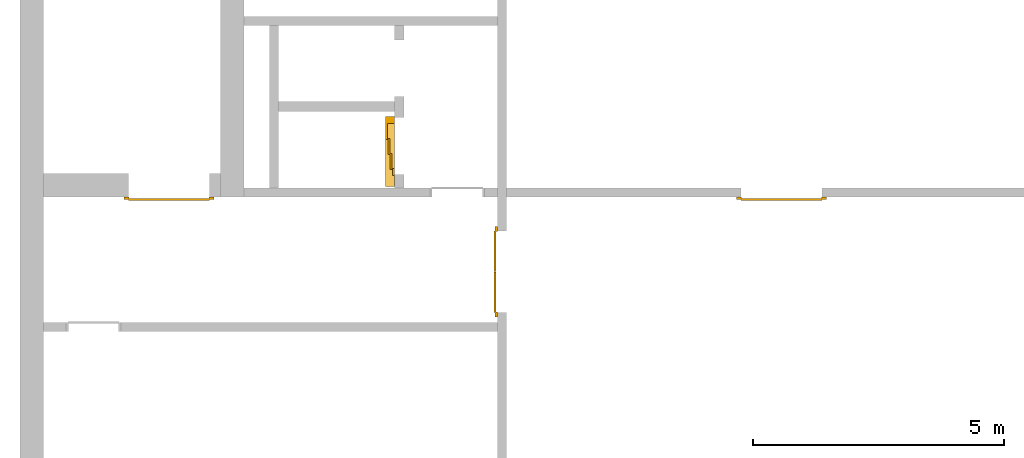
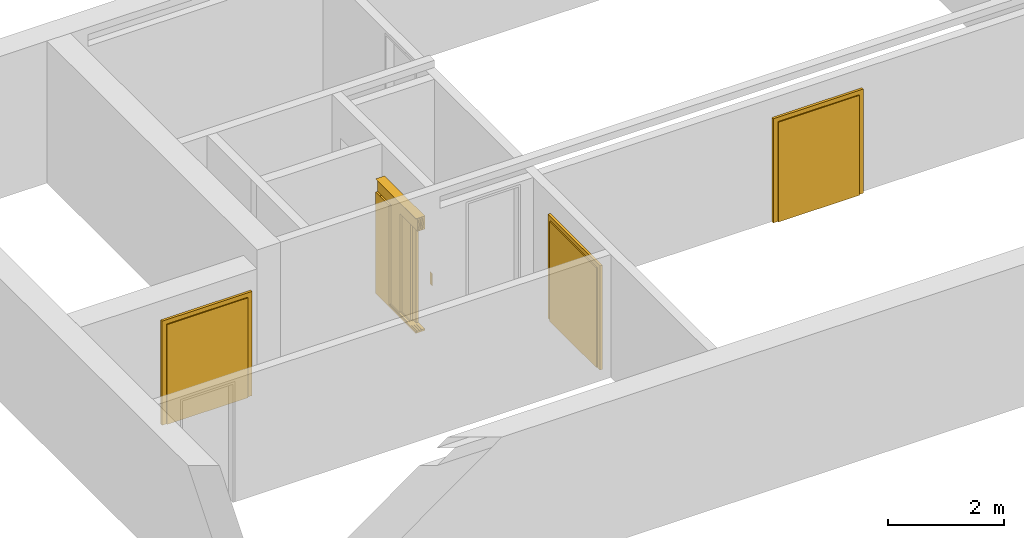
# One storey, part 2 of 3: 4 doors.
"""IFC4 building model written with IfcOpenShell, lengths in metres."""

from ifc_helpers import new_model, entity, si_unit, converted_unit, derived_unit, direction, frame, origin_with_axes, place, context, subcontext, project, spatial, polygons, source, transform, mapped, type_object, element, save


model = new_model("IFC4")

# Units and contexts
model_context = context("Model", 3, precision=1e-05, world=origin_with_axes(), true_north=direction((0.0, 1.0)))
body_context = subcontext(model_context, "Body", "Model", "MODEL_VIEW")
ifc_project = project(units=[si_unit("LENGTHUNIT", "METRE"), si_unit("AREAUNIT", "SQUARE_METRE"), si_unit("VOLUMEUNIT", "CUBIC_METRE"), converted_unit("PLANEANGLEUNIT", "DEGREE", entity("IfcPlaneAngleMeasure", 0.0174532925199433), si_unit("PLANEANGLEUNIT", "RADIAN"), dimensions=[0, 0, 0, 0, 0, 0, 0]), converted_unit("TIMEUNIT", "Year", entity("IfcTimeMeasure", 31557600.0), si_unit("TIMEUNIT", "SECOND"), dimensions=[0, 0, 1, 0, 0, 0, 0]), si_unit("MASSUNIT", "GRAM", prefix="KILO"), si_unit("THERMODYNAMICTEMPERATUREUNIT", "DEGREE_CELSIUS"), si_unit("LUMINOUSINTENSITYUNIT", "LUMEN"), si_unit("ENERGYUNIT", "JOULE", prefix="MEGA"), derived_unit("THERMALCONDUCTANCEUNIT", [(si_unit("POWERUNIT", "WATT"), 1), (si_unit("LENGTHUNIT", "METRE"), -1), (si_unit("THERMODYNAMICTEMPERATUREUNIT", "KELVIN"), -1)]), derived_unit("SPECIFICHEATCAPACITYUNIT", [(si_unit("ENERGYUNIT", "JOULE"), 1), (si_unit("MASSUNIT", "GRAM", prefix="KILO"), -1), (si_unit("THERMODYNAMICTEMPERATUREUNIT", "KELVIN"), -1)]), derived_unit("MASSDENSITYUNIT", [(si_unit("MASSUNIT", "GRAM", prefix="KILO"), 1), (si_unit("VOLUMEUNIT", "CUBIC_METRE"), -1)])], contexts=[model_context])

# Site, building, storey
site_placement = place(None, origin_with_axes())
site = spatial("IfcSite", under=ifc_project, at=site_placement, CompositionType="ELEMENT")
building_placement = place(None, origin_with_axes())
building = spatial("IfcBuilding", under=site, at=building_placement, CompositionType="ELEMENT")
storey_placement = place(None, frame((0.0, 0.0, -3.0), z_axis=(0.0, 0.0, 1.0), x_axis=(1.0, 0.0, 0.0)))
storey = spatial("IfcBuildingStorey", under=building, at=storey_placement, Name="UG", CompositionType="ELEMENT", Elevation=-3.0)

# Doors
door_type_1 = type_object("IfcDoorType", OperationType="DOUBLE_DOOR_SINGLE_SWING", PredefinedType="DOOR")
shared_shape_1 = source(origin_with_axes(), body_context, "Body", "Tessellation", [
    polygons([(-0.9, 0.0, 0.0), (-0.9, 0.0, 2.2), (-0.9, 0.03, 2.2), (-0.9, 0.03, 0.0), (-0.8, 0.0, 0.0), (-0.8, 0.0, 2.1), (-0.1101, 0.0, 2.1), (-0.0001, 0.0, 2.1), (0.8, 0.0, 2.1), (0.8, 0.0, 0.0), (0.9, 0.0, 0.0), (0.9, 0.0, 2.2), (0.9, 0.03, 2.2), (0.9, 0.03, 0.0), (0.8, 0.03, 0.0), (0.8, 0.03, 2.1), (-0.0001, 0.03, 2.1), (-0.1101, 0.03, 2.1), (-0.8, 0.03, 2.1), (-0.8, 0.03, 0.0)], [[[1, 2, 3, 4]], [[1, 5, 6, 7, 8, 9, 10, 11, 12, 2]], [[2, 12, 13, 3]], [[4, 3, 13, 14, 15, 16, 17, 18, 19, 20]], [[5, 1, 4, 20]], [[6, 5, 20, 19]], [[7, 6, 19, 18]], [[8, 7, 18, 17]], [[9, 8, 17, 16]], [[10, 9, 16, 15]], [[11, 10, 15, 14]], [[12, 11, 14, 13]]], closed=True),
    polygons([(-0.9, 0.03, 0.0), (-0.9, 0.03, 2.2), (-0.9, 0.05, 2.2), (-0.9, 0.05, 0.0), (-0.81, 0.03, 0.0), (-0.81, 0.03, 2.11), (-0.1001, 0.03, 2.11), (-0.0101, 0.03, 2.11), (0.81, 0.03, 2.11), (0.81, 0.03, 0.0), (0.9, 0.03, 0.0), (0.9, 0.03, 2.2), (0.9, 0.05, 2.2), (0.9, 0.05, 0.0), (0.81, 0.05, 0.0), (0.81, 0.05, 2.11), (-0.0101, 0.05, 2.11), (-0.1001, 0.05, 2.11), (-0.81, 0.05, 2.11), (-0.81, 0.05, 0.0)], [[[1, 2, 3, 4]], [[1, 5, 6, 7, 8, 9, 10, 11, 12, 2]], [[2, 12, 13, 3]], [[4, 3, 13, 14, 15, 16, 17, 18, 19, 20]], [[5, 1, 4, 20]], [[6, 5, 20, 19]], [[7, 6, 19, 18]], [[8, 7, 18, 17]], [[9, 8, 17, 16]], [[10, 9, 16, 15]], [[11, 10, 15, 14]], [[12, 11, 14, 13]]], closed=True),
    polygons([(-0.81, 0.07, 0.0), (-0.81, 0.07, 2.11), (-0.000499999999999945, 0.07, 2.11), (-0.000499999999999945, 0.07, 0.0), (-0.81, 0.03, 0.0), (-0.81, 0.03, 2.11), (-0.000499999999999945, 0.03, 2.11), (-0.000499999999999945, 0.03, 0.0)], [[[1, 2, 3, 4]], [[1, 5, 6, 2]], [[2, 6, 7, 3]], [[3, 7, 8, 4]], [[4, 8, 5, 1]], [[8, 7, 6, 5]]], closed=True),
    polygons([(0.81, 0.07, 0.0), (0.000499999999999945, 0.07, 0.0), (0.000499999999999945, 0.07, 2.11), (0.81, 0.07, 2.11), (0.81, 0.03, 0.0), (0.000499999999999945, 0.03, 0.0), (0.000499999999999945, 0.03, 2.11), (0.81, 0.03, 2.11)], [[[1, 2, 3, 4]], [[2, 1, 5, 6]], [[3, 2, 6, 7]], [[4, 3, 7, 8]], [[1, 4, 8, 5]], [[6, 5, 8, 7]]], closed=True),
])
door_1_placement = place(None, frame((39.968657642847, 7.05499994546755, -3.0), z_axis=(0.0, 0.0, 1.0), x_axis=(-1.0, 0.0, 0.0)))
element("IfcDoor", 1, at=door_1_placement, inside=storey, type_object=door_type_1, OverallHeight=2.11, OverallWidth=1.62, context=body_context, shape_type="MappedRepresentation", body=[
    mapped(shared_shape_1, transform((0.799999999999997, 0.0, 0.0))),
])
door_2_placement = place(None, frame((33.505, 4.76499994546756, -3.0), z_axis=(0.0, 0.0, 1.0), x_axis=(0.0, 1.0, 0.0)))
element("IfcDoor", 2, at=door_2_placement, inside=storey, type_object=door_type_1, OverallHeight=2.11, OverallWidth=1.62, context=body_context, shape_type="MappedRepresentation", body=[
    mapped(shared_shape_1, transform((0.8, 0.0, 0.0))),
])
shared_shape_2 = source(origin_with_axes(), body_context, "Body", "Tessellation", [
    polygons([(-0.9, 0.0, 0.0), (-0.9, 0.0, 2.2), (-0.9, 0.03, 2.2), (-0.9, 0.03, 0.0), (-0.8, 0.0, 0.0), (-0.8, 0.0, 2.1), (-0.1101, 0.0, 2.1), (-0.0001, 0.0, 2.1), (0.8, 0.0, 2.1), (0.8, 0.0, 0.0), (0.9, 0.0, 0.0), (0.9, 0.0, 2.2), (0.9, 0.03, 2.2), (0.9, 0.03, 0.0), (0.8, 0.03, 0.0), (0.8, 0.03, 2.1), (-0.0001, 0.03, 2.1), (-0.1101, 0.03, 2.1), (-0.8, 0.03, 2.1), (-0.8, 0.03, 0.0)], [[[1, 2, 3, 4]], [[1, 5, 6, 7, 8, 9, 10, 11, 12, 2]], [[2, 12, 13, 3]], [[4, 3, 13, 14, 15, 16, 17, 18, 19, 20]], [[5, 1, 4, 20]], [[6, 5, 20, 19]], [[7, 6, 19, 18]], [[8, 7, 18, 17]], [[9, 8, 17, 16]], [[10, 9, 16, 15]], [[11, 10, 15, 14]], [[12, 11, 14, 13]]], closed=True),
    polygons([(-0.9, 0.03, 0.0), (-0.9, 0.03, 2.2), (-0.9, 0.05, 2.2), (-0.9, 0.05, 0.0), (-0.81, 0.03, 0.0), (-0.81, 0.03, 2.11), (-0.1001, 0.03, 2.11), (-0.0101, 0.03, 2.11), (0.81, 0.03, 2.11), (0.81, 0.03, 0.0), (0.9, 0.03, 0.0), (0.9, 0.03, 2.2), (0.9, 0.05, 2.2), (0.9, 0.05, 0.0), (0.81, 0.05, 0.0), (0.81, 0.05, 2.11), (-0.0101, 0.05, 2.11), (-0.1001, 0.05, 2.11), (-0.81, 0.05, 2.11), (-0.81, 0.05, 0.0)], [[[1, 2, 3, 4]], [[1, 5, 6, 7, 8, 9, 10, 11, 12, 2]], [[2, 12, 13, 3]], [[4, 3, 13, 14, 15, 16, 17, 18, 19, 20]], [[5, 1, 4, 20]], [[6, 5, 20, 19]], [[7, 6, 19, 18]], [[8, 7, 18, 17]], [[9, 8, 17, 16]], [[10, 9, 16, 15]], [[11, 10, 15, 14]], [[12, 11, 14, 13]]], closed=True),
    polygons([(-0.81, 0.07, 0.0), (-0.81, 0.07, 2.11), (-0.000499999999999945, 0.07, 2.11), (-0.000499999999999945, 0.07, 0.0), (-0.81, 0.03, 0.0), (-0.81, 0.03, 2.11), (-0.000499999999999945, 0.03, 2.11), (-0.000499999999999945, 0.03, 0.0)], [[[1, 2, 3, 4]], [[1, 5, 6, 2]], [[2, 6, 7, 3]], [[3, 7, 8, 4]], [[4, 8, 5, 1]], [[8, 7, 6, 5]]], closed=True),
    polygons([(0.81, 0.07, 0.0), (0.000499999999999945, 0.07, 0.0), (0.000499999999999945, 0.07, 2.11), (0.81, 0.07, 2.11), (0.81, 0.03, 0.0), (0.000499999999999945, 0.03, 0.0), (0.000499999999999945, 0.03, 2.11), (0.81, 0.03, 2.11)], [[[1, 2, 3, 4]], [[2, 1, 5, 6]], [[3, 2, 6, 7]], [[4, 3, 7, 8]], [[1, 4, 8, 5]], [[6, 5, 8, 7]]], closed=True),
])
door_3_placement = place(None, frame((27.758, 7.05499994546755, -3.0), z_axis=(0.0, 0.0, 1.0), x_axis=(-1.0, 0.0, 0.0)))
element("IfcDoor", 3, at=door_3_placement, inside=storey, type_object=door_type_1, OverallHeight=2.11, OverallWidth=1.62, context=body_context, shape_type="MappedRepresentation", body=[
    mapped(shared_shape_2, transform((0.800000000000001, 0.0, 0.0))),
])
door_type_2 = type_object("IfcDoorType", Name="27", OperationType="DOUBLE_DOOR_SLIDING", PredefinedType="DOOR")
shared_shape_3 = source(origin_with_axes(), body_context, "Body", "Tessellation", [
    polygons([(-0.808333333333334, 0.135, 2.1), (-0.808333333333334, 0.135, 2.138), (0.585, 0.135, 2.138), (0.585, 0.135, 2.1), (-0.808333333333334, 0.0, 2.1), (-0.808333333333334, 0.0, 2.38), (-0.808333333333334, 0.18, 2.38), (-0.808333333333334, 0.18, 2.377), (-0.808333333333334, 0.003, 2.377), (-0.808333333333334, 0.003, 2.103), (-0.808333333333334, 0.132, 2.103), (-0.808333333333334, 0.132, 2.138), (0.585, 0.132, 2.138), (0.585, 0.132, 2.103), (0.585, 0.00299999999999992, 2.103), (0.585, 0.00299999999999992, 2.377), (0.585, 0.18, 2.377), (0.585, 0.18, 2.38), (0.585, 0.0, 2.38), (0.585, 0.0, 2.1)], [[[1, 2, 3, 4]], [[1, 5, 6, 7, 8, 9, 10, 11, 12, 2]], [[2, 12, 13, 3]], [[4, 3, 13, 14, 15, 16, 17, 18, 19, 20]], [[5, 1, 4, 20]], [[6, 5, 20, 19]], [[7, 6, 19, 18]], [[8, 7, 18, 17]], [[9, 8, 17, 16]], [[10, 9, 16, 15]], [[11, 10, 15, 14]], [[12, 11, 14, 13]]], closed=True),
    polygons([(-0.808333333333334, 0.05, 2.103), (-0.808333333333334, 0.055, 2.103), (0.585, 0.0549999999999999, 2.103), (0.585, 0.0499999999999999, 2.103), (-0.808333333333334, 0.05, 2.34), (-0.808333333333334, 0.055, 2.34), (0.585, 0.0549999999999999, 2.34), (0.585, 0.0499999999999999, 2.34)], [[[1, 2, 3, 4]], [[1, 5, 6, 2]], [[2, 6, 7, 3]], [[4, 3, 7, 8]], [[5, 1, 4, 8]], [[6, 5, 8, 7]]], closed=True),
    polygons([(-0.808333333333334, 0.05, 2.33), (-0.808333333333334, 0.04, 2.33), (0.585, 0.0399999999999999, 2.33), (0.585, 0.0499999999999999, 2.33), (-0.808333333333334, 0.05, 2.27), (-0.808333333333334, 0.04, 2.27), (0.585, 0.0399999999999999, 2.27), (0.585, 0.0499999999999999, 2.27)], [[[1, 2, 3, 4]], [[1, 5, 6, 2]], [[2, 6, 7, 3]], [[4, 3, 7, 8]], [[5, 1, 4, 8]], [[6, 5, 8, 7]]], closed=True),
    polygons([(-0.808333333333334, 0.05, 2.2), (-0.808333333333334, 0.04, 2.2), (0.585, 0.0399999999999999, 2.2), (0.585, 0.0499999999999999, 2.2), (-0.808333333333334, 0.05, 2.16), (-0.808333333333334, 0.04, 2.16), (0.585, 0.0399999999999999, 2.16), (0.585, 0.0499999999999999, 2.16)], [[[1, 2, 3, 4]], [[1, 5, 6, 2]], [[2, 6, 7, 3]], [[4, 3, 7, 8]], [[5, 1, 4, 8]], [[6, 5, 8, 7]]], closed=True),
    polygons([(-0.808333333333334, 0.05, 2.27), (-0.808333333333334, 0.03, 2.27), (0.585, 0.0299999999999999, 2.27), (0.585, 0.0499999999999999, 2.27), (-0.808333333333334, 0.05, 2.2), (-0.808333333333334, 0.03, 2.2), (0.585, 0.0299999999999999, 2.2), (0.585, 0.0499999999999999, 2.2)], [[[1, 2, 3, 4]], [[1, 5, 6, 2]], [[2, 6, 7, 3]], [[4, 3, 7, 8]], [[5, 1, 4, 8]], [[6, 5, 8, 7]]], closed=True),
    polygons([(-0.808333333333334, 0.095, 2.103), (-0.808333333333334, 0.1, 2.103), (0.585, 0.0999999999999999, 2.103), (0.585, 0.0949999999999999, 2.103), (-0.808333333333334, 0.095, 2.34), (-0.808333333333334, 0.1, 2.34), (0.585, 0.0999999999999999, 2.34), (0.585, 0.0949999999999999, 2.34)], [[[1, 2, 3, 4]], [[1, 5, 6, 2]], [[2, 6, 7, 3]], [[4, 3, 7, 8]], [[5, 1, 4, 8]], [[6, 5, 8, 7]]], closed=True),
    polygons([(-0.808333333333334, 0.095, 2.33), (-0.808333333333334, 0.085, 2.33), (0.585, 0.0849999999999999, 2.33), (0.585, 0.0949999999999999, 2.33), (-0.808333333333334, 0.095, 2.27), (-0.808333333333334, 0.085, 2.27), (0.585, 0.0849999999999999, 2.27), (0.585, 0.0949999999999999, 2.27)], [[[1, 2, 3, 4]], [[1, 5, 6, 2]], [[2, 6, 7, 3]], [[4, 3, 7, 8]], [[5, 1, 4, 8]], [[6, 5, 8, 7]]], closed=True),
    polygons([(-0.808333333333334, 0.095, 2.2), (-0.808333333333334, 0.085, 2.2), (0.585, 0.0849999999999999, 2.2), (0.585, 0.0949999999999999, 2.2), (-0.808333333333334, 0.095, 2.16), (-0.808333333333334, 0.085, 2.16), (0.585, 0.0849999999999999, 2.16), (0.585, 0.0949999999999999, 2.16)], [[[1, 2, 3, 4]], [[1, 5, 6, 2]], [[2, 6, 7, 3]], [[4, 3, 7, 8]], [[5, 1, 4, 8]], [[6, 5, 8, 7]]], closed=True),
    polygons([(-0.808333333333334, 0.095, 2.27), (-0.808333333333334, 0.075, 2.27), (0.585, 0.0749999999999999, 2.27), (0.585, 0.0949999999999999, 2.27), (-0.808333333333334, 0.095, 2.2), (-0.808333333333334, 0.075, 2.2), (0.585, 0.0749999999999999, 2.2), (0.585, 0.0949999999999999, 2.2)], [[[1, 2, 3, 4]], [[1, 5, 6, 2]], [[2, 6, 7, 3]], [[4, 3, 7, 8]], [[5, 1, 4, 8]], [[6, 5, 8, 7]]], closed=True),
    polygons([(-0.808333333333334, 0.14, 2.103), (-0.808333333333334, 0.145, 2.103), (0.585, 0.145, 2.103), (0.585, 0.14, 2.103), (-0.808333333333334, 0.14, 2.34), (-0.808333333333334, 0.145, 2.34), (0.585, 0.145, 2.34), (0.585, 0.14, 2.34)], [[[1, 2, 3, 4]], [[1, 5, 6, 2]], [[2, 6, 7, 3]], [[4, 3, 7, 8]], [[5, 1, 4, 8]], [[6, 5, 8, 7]]], closed=True),
    polygons([(-0.808333333333334, 0.14, 2.33), (-0.808333333333334, 0.13, 2.33), (0.585, 0.13, 2.33), (0.585, 0.14, 2.33), (-0.808333333333334, 0.14, 2.27), (-0.808333333333334, 0.13, 2.27), (0.585, 0.13, 2.27), (0.585, 0.14, 2.27)], [[[1, 2, 3, 4]], [[1, 5, 6, 2]], [[2, 6, 7, 3]], [[4, 3, 7, 8]], [[5, 1, 4, 8]], [[6, 5, 8, 7]]], closed=True),
    polygons([(-0.808333333333334, 0.14, 2.2), (-0.808333333333334, 0.13, 2.2), (0.585, 0.13, 2.2), (0.585, 0.14, 2.2), (-0.808333333333334, 0.14, 2.16), (-0.808333333333334, 0.13, 2.16), (0.585, 0.13, 2.16), (0.585, 0.14, 2.16)], [[[1, 2, 3, 4]], [[1, 5, 6, 2]], [[2, 6, 7, 3]], [[4, 3, 7, 8]], [[5, 1, 4, 8]], [[6, 5, 8, 7]]], closed=True),
    polygons([(-0.808333333333334, 0.14, 2.27), (-0.808333333333334, 0.12, 2.27), (0.585, 0.12, 2.27), (0.585, 0.14, 2.27), (-0.808333333333334, 0.14, 2.2), (-0.808333333333334, 0.12, 2.2), (0.585, 0.12, 2.2), (0.585, 0.14, 2.2)], [[[1, 2, 3, 4]], [[1, 5, 6, 2]], [[2, 6, 7, 3]], [[4, 3, 7, 8]], [[5, 1, 4, 8]], [[6, 5, 8, 7]]], closed=True),
    polygons([(-0.808333333333334, 0.0, 0.0), (-0.808333333333334, 0.0, -0.04), (0.585, 0.0, -0.04), (0.585, 0.0, 0.0), (-0.808333333333334, 0.065, 0.0), (-0.808333333333334, 0.065, -0.01), (-0.808333333333334, 0.075, -0.01), (-0.808333333333334, 0.075, 0.0), (-0.808333333333334, 0.11, 0.0), (-0.808333333333334, 0.11, -0.01), (-0.808333333333334, 0.12, -0.01), (-0.808333333333334, 0.12, 0.0), (-0.808333333333334, 0.155, 0.0), (-0.808333333333334, 0.155, -0.01), (-0.808333333333334, 0.165, -0.01), (-0.808333333333334, 0.165, 0.0), (-0.808333333333334, 0.18, 0.0), (-0.808333333333334, 0.18, -0.04), (0.585, 0.18, -0.04), (0.585, 0.18, 0.0), (0.585, 0.165, 0.0), (0.585, 0.165, -0.01), (0.585, 0.155, -0.01), (0.585, 0.155, 0.0), (0.585, 0.12, 0.0), (0.585, 0.12, -0.01), (0.585, 0.11, -0.01), (0.585, 0.11, 0.0), (0.585, 0.0749999999999999, 0.0), (0.585, 0.0749999999999999, -0.01), (0.585, 0.0649999999999999, -0.01), (0.585, 0.0649999999999999, 0.0)], [[[1, 2, 3, 4]], [[1, 5, 6, 7, 8, 9, 10, 11, 12, 13, 14, 15, 16, 17, 18, 2]], [[2, 18, 19, 3]], [[4, 3, 19, 20, 21, 22, 23, 24, 25, 26, 27, 28, 29, 30, 31, 32]], [[5, 1, 4, 32]], [[6, 5, 32, 31]], [[7, 6, 31, 30]], [[8, 7, 30, 29]], [[9, 8, 29, 28]], [[10, 9, 28, 27]], [[11, 10, 27, 26]], [[12, 11, 26, 25]], [[13, 12, 25, 24]], [[14, 13, 24, 23]], [[15, 14, 23, 22]], [[16, 15, 22, 21]], [[17, 16, 21, 20]], [[18, 17, 20, 19]]], closed=True),
    polygons([(-0.45, 0.0, 0.0), (-0.45, 0.045, 0.0), (-0.45, 0.0449999999999999, 2.1), (-0.45, 0.0, 2.1), (-0.585, 0.0, 0.0), (-0.585, 0.045, 0.0), (-0.585, 0.0449999999999999, 2.1), (-0.585, 0.0, 2.1)], [[[1, 2, 3, 4]], [[1, 5, 6, 2]], [[2, 6, 7, 3]], [[4, 3, 7, 8]], [[5, 1, 4, 8]], [[6, 5, 8, 7]]], closed=True),
    polygons([(0.585, 0.0, 0.0), (0.585, 0.18, 0.0), (0.585, 0.18, 2.1), (0.585, 0.0, 2.1), (0.45, 0.0, 0.0), (0.45, 0.18, 0.0), (0.45, 0.18, 2.1), (0.45, 0.0, 2.1)], [[[1, 2, 3, 4]], [[1, 5, 6, 2]], [[2, 6, 7, 3]], [[4, 3, 7, 8]], [[5, 1, 4, 8]], [[6, 5, 8, 7]]], closed=True),
    polygons([(-0.745, -0.18, 0.8), (-0.665, -0.18, 0.8), (-0.665, -0.183, 0.8), (-0.745, -0.183, 0.8), (-0.745, -0.18, 1.06), (-0.665, -0.18, 1.06), (-0.735, -0.18, 1.03), (-0.735, -0.18, 0.94), (-0.675, -0.18, 0.94), (-0.675, -0.18, 1.03), (-0.715, -0.18, 0.84), (-0.695, -0.18, 0.84), (-0.695, -0.18, 0.86), (-0.715, -0.18, 0.86), (-0.715, -0.18, 0.88), (-0.695, -0.18, 0.88), (-0.695, -0.18, 0.9), (-0.715, -0.18, 0.9), (-0.665, -0.183, 1.06), (-0.745, -0.183, 1.06), (-0.735, -0.183, 1.03), (-0.675, -0.183, 1.03), (-0.675, -0.183, 0.94), (-0.735, -0.183, 0.94), (-0.715, -0.183, 0.84), (-0.715, -0.183, 0.86), (-0.695, -0.183, 0.86), (-0.695, -0.183, 0.84), (-0.715, -0.183, 0.88), (-0.715, -0.183, 0.9), (-0.695, -0.183, 0.9), (-0.695, -0.183, 0.88)], [[[1, 2, 3, 4]], [[1, 5, 6, 2], [7, 8, 9, 10], [11, 12, 13, 14], [15, 16, 17, 18]], [[2, 6, 19, 3]], [[4, 3, 19, 20], [21, 22, 23, 24], [25, 26, 27, 28], [29, 30, 31, 32]], [[5, 1, 4, 20]], [[6, 5, 20, 19]], [[8, 7, 21, 24]], [[9, 8, 24, 23]], [[10, 9, 23, 22]], [[7, 10, 22, 21]], [[12, 11, 25, 28]], [[13, 12, 28, 27]], [[14, 13, 27, 26]], [[11, 14, 26, 25]], [[16, 15, 29, 32]], [[17, 16, 32, 31]], [[18, 17, 31, 30]], [[15, 18, 30, 29]]], closed=True),
    polygons([(-0.735, -0.18, 0.94), (-0.675, -0.18, 0.94), (-0.675, -0.1825, 0.94), (-0.735, -0.1825, 0.94), (-0.735, -0.18, 1.03), (-0.675, -0.18, 1.03), (-0.675, -0.1825, 1.03), (-0.735, -0.1825, 1.03)], [[[1, 2, 3, 4]], [[1, 5, 6, 2]], [[2, 6, 7, 3]], [[4, 3, 7, 8]], [[5, 1, 4, 8]], [[6, 5, 8, 7]]], closed=True),
    polygons([(-0.721, -0.183, 1.005), (-0.715, -0.183, 1.021), (-0.709, -0.183, 1.005)], [[[1, 2, 3]]], closed=False),
    polygons([(-0.695, -0.183, 1.005), (-0.701, -0.183, 1.021), (-0.689, -0.183, 1.021)], [[[1, 2, 3]]], closed=False),
    polygons([(-0.707727272727273, -0.1835, 0.982), (-0.707727272727273, -0.1835, 0.971636363636364), (-0.709090909090909, -0.1835, 0.970272727272727), (-0.710454545454546, -0.1835, 0.971636363636364), (-0.710454545454546, -0.1835, 0.982), (-0.709090909090909, -0.1835, 0.983363636363636)], [[[1, 2, 3, 4, 5, 6]]], closed=False),
    polygons([(-0.707727272727273, -0.1835, 0.968363636363636), (-0.707727272727273, -0.1835, 0.958), (-0.709090909090909, -0.1835, 0.956636363636364), (-0.710454545454546, -0.1835, 0.958), (-0.710454545454546, -0.1835, 0.968363636363636), (-0.709090909090909, -0.1835, 0.969727272727273)], [[[1, 2, 3, 4, 5, 6]]], closed=False),
    polygons([(-0.688909090909091, -0.1835, 0.982272727272727), (-0.699272727272727, -0.1835, 0.982272727272727), (-0.700636363636364, -0.1835, 0.983636363636364), (-0.699272727272727, -0.1835, 0.985), (-0.688909090909091, -0.1835, 0.985), (-0.687545454545455, -0.1835, 0.983636363636364)], [[[1, 2, 3, 4, 5, 6]]], closed=False),
    polygons([(-0.685909090909091, -0.1835, 0.982), (-0.685909090909091, -0.1835, 0.971636363636364), (-0.687272727272727, -0.1835, 0.970272727272727), (-0.688636363636364, -0.1835, 0.971636363636364), (-0.688636363636364, -0.1835, 0.982), (-0.687272727272727, -0.1835, 0.983363636363636)], [[[1, 2, 3, 4, 5, 6]]], closed=False),
    polygons([(-0.688909090909091, -0.1835, 0.968636363636364), (-0.699272727272727, -0.1835, 0.968636363636364), (-0.700636363636364, -0.1835, 0.97), (-0.699272727272727, -0.1835, 0.971363636363636), (-0.688909090909091, -0.1835, 0.971363636363636), (-0.687545454545455, -0.1835, 0.97)], [[[1, 2, 3, 4, 5, 6]]], closed=False),
    polygons([(-0.699545454545455, -0.1835, 0.968363636363636), (-0.699545454545455, -0.1835, 0.958), (-0.700909090909091, -0.1835, 0.956636363636364), (-0.702272727272727, -0.1835, 0.958), (-0.702272727272727, -0.1835, 0.968363636363636), (-0.700909090909091, -0.1835, 0.969727272727273)], [[[1, 2, 3, 4, 5, 6]]], closed=False),
    polygons([(-0.688909090909091, -0.1835, 0.955), (-0.699272727272727, -0.1835, 0.955), (-0.700636363636364, -0.1835, 0.956363636363636), (-0.699272727272727, -0.1835, 0.957727272727273), (-0.688909090909091, -0.1835, 0.957727272727273), (-0.687545454545455, -0.1835, 0.956363636363636)], [[[1, 2, 3, 4, 5, 6]]], closed=False),
    polygons([(-0.695, -0.18, 0.84), (-0.715, -0.18, 0.84), (-0.715, -0.18, 0.86), (-0.695, -0.18, 0.86), (-0.694999999905229, -0.1815, 0.839999999610484), (-0.715000000389516, -0.1815, 0.839999999610484), (-0.715000000389516, -0.1815, 0.860000000094772), (-0.694999999905229, -0.1815, 0.860000000094772), (-0.696400000320971, -0.182900000415742, 0.841400000026226), (-0.713599999973774, -0.182900000415742, 0.841400000026226), (-0.713599999973774, -0.182900000415742, 0.858599999679029), (-0.696400000320971, -0.182900000415742, 0.858599999679029)], [[[1, 2, 3, 4]], [[2, 1, 5, 6]], [[3, 2, 6, 7]], [[4, 3, 7, 8]], [[1, 4, 8, 5]], [[6, 5, 9, 10]], [[7, 6, 10, 11]], [[8, 7, 11, 12]], [[5, 8, 12, 9]], [[11, 10, 9, 12]]], closed=True),
    polygons([(-0.7, -0.183, 0.855), (-0.705, -0.183, 0.844), (-0.71, -0.183, 0.855)], [[[1, 2, 3]]], closed=False),
    polygons([(-0.695, -0.18, 0.88), (-0.715, -0.18, 0.88), (-0.715, -0.18, 0.9), (-0.695, -0.18, 0.9), (-0.694999999905229, -0.1815, 0.879999999610484), (-0.715000000389516, -0.1815, 0.879999999610484), (-0.715000000389516, -0.1815, 0.900000000094772), (-0.694999999905229, -0.1815, 0.900000000094772), (-0.696400000320971, -0.182900000415742, 0.881400000026226), (-0.713599999973774, -0.182900000415742, 0.881400000026226), (-0.713599999973774, -0.182900000415742, 0.898599999679029), (-0.696400000320971, -0.182900000415742, 0.898599999679029)], [[[1, 2, 3, 4]], [[2, 1, 5, 6]], [[3, 2, 6, 7]], [[4, 3, 7, 8]], [[1, 4, 8, 5]], [[6, 5, 9, 10]], [[7, 6, 10, 11]], [[8, 7, 11, 12]], [[5, 8, 12, 9]], [[11, 10, 9, 12]]], closed=True),
    polygons([(-0.7, -0.183, 0.885), (-0.71, -0.183, 0.885), (-0.705, -0.183, 0.896)], [[[1, 2, 3]]], closed=False),
    polygons([(0.126666666666667, 0.14, 0.003), (0.126666666666667, 0.18, 0.003), (0.445, 0.18, 0.003), (0.445, 0.14, 0.003), (0.126666666666667, 0.14, 2.1), (0.126666666666667, 0.18, 2.1), (0.445, 0.18, 2.1), (0.445, 0.14, 2.1)], [[[1, 2, 3, 4]], [[5, 6, 2, 1]], [[2, 6, 7, 3]], [[4, 3, 7, 8]], [[1, 4, 8, 5]], [[8, 7, 6, 5]]], closed=True),
    polygons([(-0.171666666666667, 0.095, 0.003), (-0.171666666666667, 0.135, 0.003), (0.146666666666667, 0.135, 0.003), (0.146666666666667, 0.095, 0.003), (-0.171666666666667, 0.095, 2.1), (-0.171666666666667, 0.135, 2.1), (0.146666666666667, 0.135, 2.1), (0.146666666666667, 0.095, 2.1)], [[[1, 2, 3, 4]], [[5, 6, 2, 1]], [[2, 6, 7, 3]], [[4, 3, 7, 8]], [[1, 4, 8, 5]], [[8, 7, 6, 5]]], closed=True),
    polygons([(-0.47, 0.05, 0.003), (-0.47, 0.09, 0.003), (-0.151666666666667, 0.09, 0.003), (-0.151666666666667, 0.05, 0.003), (-0.47, 0.05, 2.1), (-0.47, 0.09, 2.1), (-0.151666666666667, 0.09, 2.1), (-0.151666666666667, 0.05, 2.1)], [[[1, 2, 3, 4]], [[5, 6, 2, 1]], [[2, 6, 7, 3]], [[4, 3, 7, 8]], [[1, 4, 8, 5]], [[8, 7, 6, 5]]], closed=True),
])
door_4_placement = place(None, frame((31.638, 7.61999994546756, -3.0), z_axis=(0.0, 0.0, 1.0), x_axis=(0.0, 1.0, 0.0)))
element("IfcDoor", 4, at=door_4_placement, inside=storey, type_object=door_type_2, OverallHeight=2.25, OverallWidth=1.13, context=body_context, shape_type="MappedRepresentation", body=[
    mapped(shared_shape_3, transform((0.450000000000001, 0.18, 0.0))),
])

save(model, "model.ifc")
